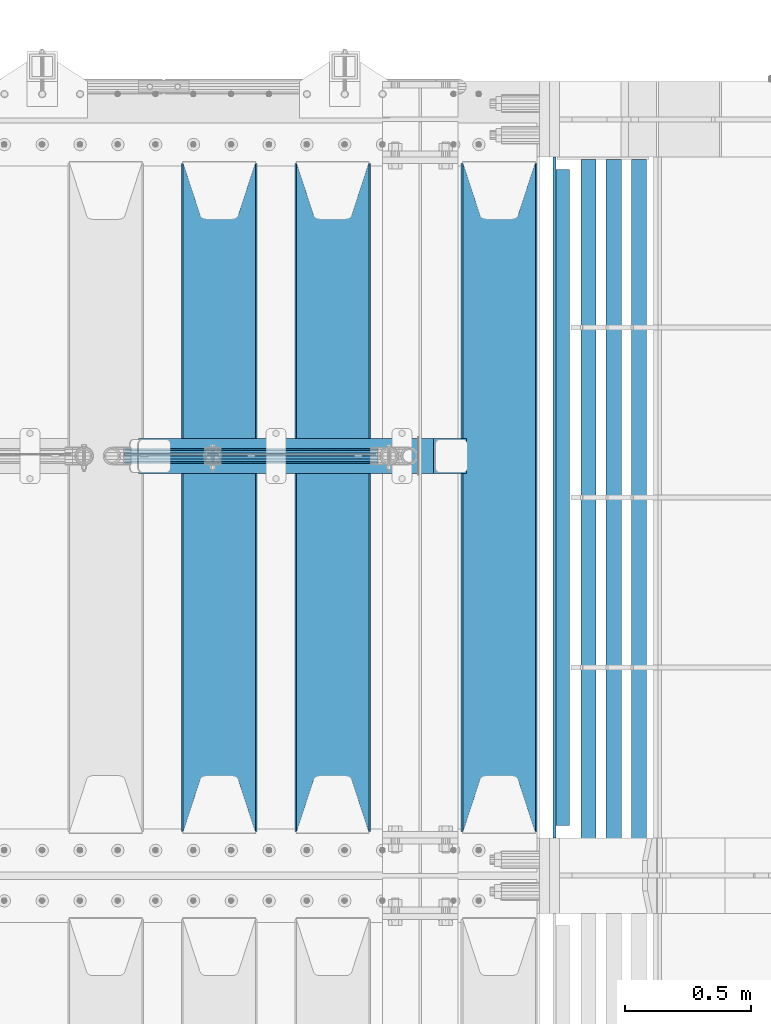
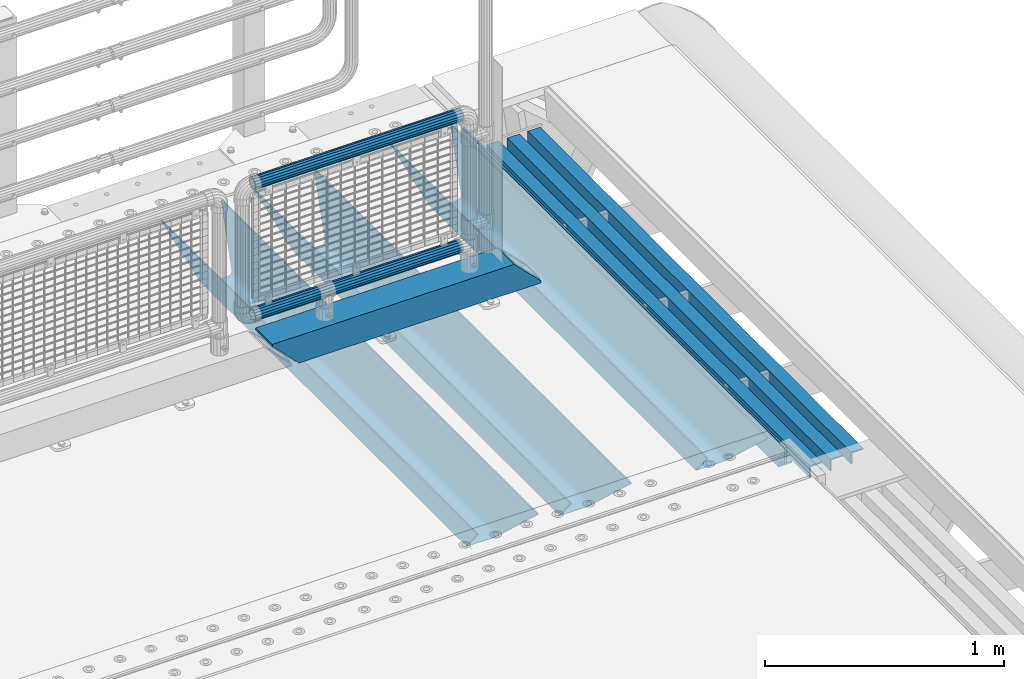
# One storey, part 136 of 242: 10 beams.
"""IFC2X3 building model written with IfcOpenShell, lengths in millimetres."""

from ifc_helpers import new_model, si_unit, frame, origin_with_axes, place, context, subcontext, project, spatial, faceted_brep, material, type_object, element, save


model = new_model("IFC2X3")

# Units and contexts
model_context = context("Model", 3, precision=1e-05, world=origin_with_axes())
body_context = subcontext(model_context, "Body", "Model", "MODEL_VIEW")
ifc_project = project(units=[si_unit("LENGTHUNIT", "METRE", prefix="MILLI"), si_unit("AREAUNIT", "SQUARE_METRE"), si_unit("VOLUMEUNIT", "CUBIC_METRE"), si_unit("MASSUNIT", "GRAM", prefix="KILO"), si_unit("TIMEUNIT", "SECOND"), si_unit("PLANEANGLEUNIT", "RADIAN"), si_unit("SOLIDANGLEUNIT", "STERADIAN"), si_unit("THERMODYNAMICTEMPERATUREUNIT", "DEGREE_CELSIUS"), si_unit("LUMINOUSINTENSITYUNIT", "LUMEN")], contexts=[model_context])

# Site, building, storey
site_placement = place(None, origin_with_axes())
site = spatial("IfcSite", under=ifc_project, at=site_placement, CompositionType="ELEMENT")
building_placement = place(site_placement, origin_with_axes())
building = spatial("IfcBuilding", under=site, at=building_placement, Name="Standard", CompositionType="ELEMENT")
storey_placement = place(building_placement, origin_with_axes())
storey = spatial("IfcBuildingStorey", under=building, at=storey_placement, Name="Undefined", CompositionType="ELEMENT", Elevation=0.0)

# Beams
ifc_material_1 = material()
beam_type_1 = type_object("IfcBeamType", PredefinedType="NOTDEFINED")
beam_1_placement = place(storey_placement, frame((-23705.4, -19335.5, 298.170000000001), z_axis=(0.0, 0.0, 1.0), x_axis=(1.0, 0.0, 0.0)))
element("IfcBeam", 1, at=beam_1_placement, inside=storey, type_object=beam_type_1, material=ifc_material_1, context=body_context, shape_type="Brep", body=[
    faceted_brep([(0.0, -25.3499999999985, 0.0), (0.0, -23.4203461491597, 9.70102501045403), (1005.0, -23.4203461491597, 9.70102501045506), (1005.0, -25.3499999999985, 0.0), (0.0, -17.9251569030785, 17.9251569030785), (1005.0, -17.9251569030785, 17.925156903079), (0.0, -9.70102501045403, 23.4203461491597), (1005.0, -9.70102501045403, 23.4203461491611), (0.0, 0.0, 25.3499999999985), (1005.0, 0.0, 25.35), (0.0, 9.70102501045403, 23.4203461491597), (1005.0, 9.70102501045403, 23.4203461491611), (0.0, 17.9251569030785, 17.9251569030785), (1005.0, 17.9251569030785, 17.925156903079), (0.0, 23.4203461491597, 9.70102501045403), (1005.0, 23.4203461491597, 9.701025010455), (0.0, 25.3499999999985, 0.0), (1005.0, 25.3499999999985, 0.0), (0.0, 23.4203461491597, -9.70102501045403), (1005.0, 23.4203461491597, -9.70102501045506), (0.0, 17.9251569030785, -17.9251569030785), (1005.0, 17.9251569030785, -17.925156903079), (0.0, 9.70102501045403, -23.4203461491597), (1005.0, 9.70102501045403, -23.4203461491611), (0.0, 0.0, -25.3499999999985), (1005.0, 0.0, -25.35), (0.0, -9.70102501045403, -23.4203461491597), (1005.0, -9.70102501045403, -23.4203461491611), (0.0, -17.9251569030785, -17.9251569030785), (1005.0, -17.9251569030785, -17.925156903079), (0.0, -23.4203461491597, -9.70102501045403), (1005.0, -23.4203461491597, -9.701025010455), (0.0, -30.1500000000015, 0.0), (0.0, -27.8549679052157, -11.5379054858058), (1005.0, -27.8549679052157, -11.5379054858075), (1005.0, -30.1500000000015, 0.0), (0.0, -21.3192694527752, -21.3192694527752), (1005.0, -21.3192694527752, -21.3192694527744), (0.0, -11.5379054858058, -27.8549679052157), (1005.0, -11.5379054858058, -27.8549679052153), (0.0, 0.0, -30.1500000000015), (1005.0, 0.0, -30.15), (0.0, 11.5379054858058, -27.8549679052157), (1005.0, 11.5379054858058, -27.8549679052153), (0.0, 21.3192694527752, -21.3192694527752), (1005.0, 21.3192694527752, -21.3192694527744), (0.0, 27.8549679052157, -11.5379054858058), (1005.0, 27.8549679052157, -11.5379054858075), (0.0, 30.1500000000015, 0.0), (1005.0, 30.1500000000015, 0.0), (0.0, 27.8549679052157, 11.5379054858058), (1005.0, 27.8549679052157, 11.5379054858075), (0.0, 21.3192694527752, 21.3192694527752), (1005.0, 21.3192694527752, 21.3192694527744), (0.0, 11.5379054858058, 27.8549679052157), (1005.0, 11.5379054858058, 27.8549679052153), (0.0, 0.0, 30.1500000000015), (1005.0, 0.0, 30.15), (0.0, -11.5379054858058, 27.8549679052157), (1005.0, -11.5379054858058, 27.8549679052153), (0.0, -21.3192694527752, 21.3192694527752), (1005.0, -21.3192694527752, 21.3192694527744), (0.0, -27.8549679052157, 11.5379054858058), (1005.0, -27.8549679052157, 11.5379054858075)], [[[0, 1, 2, 3]], [[1, 4, 5, 2]], [[4, 6, 7, 5]], [[6, 8, 9, 7]], [[8, 10, 11, 9]], [[10, 12, 13, 11]], [[12, 14, 15, 13]], [[14, 16, 17, 15]], [[16, 18, 19, 17]], [[18, 20, 21, 19]], [[20, 22, 23, 21]], [[22, 24, 25, 23]], [[24, 26, 27, 25]], [[26, 28, 29, 27]], [[28, 30, 31, 29]], [[30, 0, 3, 31]], [[32, 33, 34, 35]], [[33, 36, 37, 34]], [[36, 38, 39, 37]], [[38, 40, 41, 39]], [[40, 42, 43, 41]], [[42, 44, 45, 43]], [[44, 46, 47, 45]], [[46, 48, 49, 47]], [[48, 50, 51, 49]], [[50, 52, 53, 51]], [[52, 54, 55, 53]], [[54, 56, 57, 55]], [[56, 58, 59, 57]], [[58, 60, 61, 59]], [[60, 62, 63, 61]], [[62, 32, 35, 63]], [[37, 39, 41, 43, 45, 47, 49, 51, 53, 55, 57, 59, 61, 63, 35, 34], [5, 7, 9, 11, 13, 15, 17, 19, 21, 23, 25, 27, 29, 31, 3, 2]], [[62, 60, 58, 56, 54, 52, 50, 48, 46, 44, 42, 40, 38, 36, 33, 32], [30, 28, 26, 24, 22, 20, 18, 16, 14, 12, 10, 8, 6, 4, 1, 0]]]),
])
beam_2_placement = place(storey_placement, frame((-23706.0, -19335.5, 969.85), z_axis=(0.0, 0.0, 1.0), x_axis=(1.0, 0.0, 0.0)))
element("IfcBeam", 2, at=beam_2_placement, inside=storey, type_object=beam_type_1, material=ifc_material_1, context=body_context, shape_type="Brep", body=[
    faceted_brep([(0.0, -25.3499999999985, 0.0), (0.0, -23.4203461491597, 9.70102501045403), (1005.0, -23.4203461491597, 9.70102501045506), (1005.0, -25.3499999999985, 0.0), (0.0, -17.9251569030785, 17.9251569030785), (1005.0, -17.9251569030785, 17.925156903079), (0.0, -9.70102501045403, 23.4203461491597), (1005.0, -9.70102501045403, 23.4203461491611), (0.0, 0.0, 25.3499999999985), (1005.0, 0.0, 25.35), (0.0, 9.70102501045403, 23.4203461491597), (1005.0, 9.70102501045403, 23.4203461491611), (0.0, 17.9251569030785, 17.9251569030785), (1005.0, 17.9251569030785, 17.925156903079), (0.0, 23.4203461491597, 9.70102501045403), (1005.0, 23.4203461491597, 9.701025010455), (0.0, 25.3499999999985, 0.0), (1005.0, 25.3499999999985, 0.0), (0.0, 23.4203461491597, -9.70102501045403), (1005.0, 23.4203461491597, -9.70102501045506), (0.0, 17.9251569030785, -17.9251569030785), (1005.0, 17.9251569030785, -17.925156903079), (0.0, 9.70102501045403, -23.4203461491597), (1005.0, 9.70102501045403, -23.4203461491611), (0.0, 0.0, -25.3499999999985), (1005.0, 0.0, -25.35), (0.0, -9.70102501045403, -23.4203461491597), (1005.0, -9.70102501045403, -23.4203461491611), (0.0, -17.9251569030785, -17.9251569030785), (1005.0, -17.9251569030785, -17.925156903079), (0.0, -23.4203461491597, -9.70102501045403), (1005.0, -23.4203461491597, -9.701025010455), (0.0, -30.1500000000015, 0.0), (0.0, -27.8549679052157, -11.5379054858058), (1005.0, -27.8549679052157, -11.5379054858075), (1005.0, -30.1500000000015, 0.0), (0.0, -21.3192694527752, -21.3192694527752), (1005.0, -21.3192694527752, -21.3192694527744), (0.0, -11.5379054858058, -27.8549679052157), (1005.0, -11.5379054858058, -27.8549679052153), (0.0, 0.0, -30.1500000000015), (1005.0, 0.0, -30.15), (0.0, 11.5379054858058, -27.8549679052157), (1005.0, 11.5379054858058, -27.8549679052153), (0.0, 21.3192694527752, -21.3192694527752), (1005.0, 21.3192694527752, -21.3192694527744), (0.0, 27.8549679052157, -11.5379054858058), (1005.0, 27.8549679052157, -11.5379054858075), (0.0, 30.1500000000015, 0.0), (1005.0, 30.1500000000015, 0.0), (0.0, 27.8549679052157, 11.5379054858058), (1005.0, 27.8549679052157, 11.5379054858075), (0.0, 21.3192694527752, 21.3192694527752), (1005.0, 21.3192694527752, 21.3192694527744), (0.0, 11.5379054858058, 27.8549679052157), (1005.0, 11.5379054858058, 27.8549679052153), (0.0, 0.0, 30.1500000000015), (1005.0, 0.0, 30.15), (0.0, -11.5379054858058, 27.8549679052157), (1005.0, -11.5379054858058, 27.8549679052153), (0.0, -21.3192694527752, 21.3192694527752), (1005.0, -21.3192694527752, 21.3192694527744), (0.0, -27.8549679052157, 11.5379054858058), (1005.0, -27.8549679052157, 11.5379054858075)], [[[0, 1, 2, 3]], [[1, 4, 5, 2]], [[4, 6, 7, 5]], [[6, 8, 9, 7]], [[8, 10, 11, 9]], [[10, 12, 13, 11]], [[12, 14, 15, 13]], [[14, 16, 17, 15]], [[16, 18, 19, 17]], [[18, 20, 21, 19]], [[20, 22, 23, 21]], [[22, 24, 25, 23]], [[24, 26, 27, 25]], [[26, 28, 29, 27]], [[28, 30, 31, 29]], [[30, 0, 3, 31]], [[32, 33, 34, 35]], [[33, 36, 37, 34]], [[36, 38, 39, 37]], [[38, 40, 41, 39]], [[40, 42, 43, 41]], [[42, 44, 45, 43]], [[44, 46, 47, 45]], [[46, 48, 49, 47]], [[48, 50, 51, 49]], [[50, 52, 53, 51]], [[52, 54, 55, 53]], [[54, 56, 57, 55]], [[56, 58, 59, 57]], [[58, 60, 61, 59]], [[60, 62, 63, 61]], [[62, 32, 35, 63]], [[37, 39, 41, 43, 45, 47, 49, 51, 53, 55, 57, 59, 61, 63, 35, 34], [5, 7, 9, 11, 13, 15, 17, 19, 21, 23, 25, 27, 29, 31, 3, 2]], [[62, 60, 58, 56, 54, 52, 50, 48, 46, 44, 42, 40, 38, 36, 33, 32], [30, 28, 26, 24, 22, 20, 18, 16, 14, 12, 10, 8, 6, 4, 1, 0]]]),
])
beam_type_2 = type_object("IfcBeamType", PredefinedType="NOTDEFINED")
beam_3_placement = place(storey_placement, frame((-23650.0, -19335.5, 98.0199999999977), z_axis=(0.0, 0.0, 1.0), x_axis=(1.0, 0.0, 0.0)))
element("IfcBeam", 3, at=beam_3_placement, inside=storey, type_object=beam_type_2, material=ifc_material_1, context=body_context, shape_type="Brep", body=[
    faceted_brep([(0.0, 70.0, 70.0), (0.0, -70.0, 70.0), (1170.88846984783, -70.0, 70.0), (1170.88846984783, 70.0, 70.0), (1301.0, -60.0, -60.0), (1301.0, 60.0, -60.0), (119.989831466442, 60.0, -60.0), (119.989910626176, -60.0, -60.0), (1180.89643628727, -60.0, 60.0), (2.49929144047201e-09, -60.0000000000073, 60.0), (2.49928966411517e-09, 59.9999999999964, 60.0), (1180.89643628727, 60.0, 60.0), (1301.0, -70.0, -60.0079600980719), (1301.0, 70.0, -60.0079600980719), (1301.0, -70.0, -70.0), (1301.0, 70.0, -70.0), (129.999907566686, 70.0, -70.0), (0.0, 70.0, 59.8689646261584), (0.0, -70.0, 59.8690568861577), (129.99999991971, -70.0, -70.0)], [[[0, 1, 2, 3]], [[4, 5, 6, 7]], [[8, 4, 7, 9]], [[9, 10, 11, 8]], [[5, 11, 10, 6]], [[2, 12, 4, 8, 11, 5, 13, 3]], [[4, 12, 14, 15, 13, 5]], [[0, 3, 13, 15, 16, 17]], [[9, 18, 1, 0, 17, 10]], [[14, 12, 2, 1, 18, 19]], [[15, 14, 19, 16]], [[18, 9, 7, 6, 10, 17, 16, 19]]]),
])
ifc_material_2 = material(Name="STEEL/S355N")
beam_type_3 = type_object("IfcBeamType", PredefinedType="NOTDEFINED")
beam_4_placement = place(storey_placement, frame((-22220.0, -20825.0, -115.0), z_axis=(0.0, 0.0, 1.0), x_axis=(0.0, 1.0, 0.0)))
element("IfcBeam", 4, at=beam_4_placement, inside=storey, type_object=beam_type_3, material=ifc_material_2, context=body_context, shape_type="Brep", body=[
    faceted_brep([(0.0, 150.0, 115.0), (0.0, 143.689999999999, 115.0), (2650.00000000297, 143.689999999999, 115.0), (2650.00000000297, 150.0, 115.0), (2650.00000000297, 142.059565218402, 110.000000003099), (2650.00000000297, 148.369565218403, 110.000000003099), (2441.90079219209, -80.1103600731112, -98.0992078077845), (2437.7588105432, -77.5672621345584, -102.241189456673), (2434.06523489747, -74.4080125315522, -105.934765102404), (2430.91086095089, -70.710272125576, -109.089139048974), (2428.37322971128, -66.5649389910068, -111.626770288588), (2426.51472138055, -62.0739139532889, -113.485278619323), (2425.38102192092, -57.3475956567672, -114.618978078955), (2424.99999999987, -52.5021667386536, -115.0), (2424.99999999987, 52.5021667386536, -115.0), (2425.38102192092, 57.3475956567672, -114.618978078955), (2426.51472138055, 62.0739139532889, -113.485278619323), (2428.37322971128, 66.5649389910068, -111.626770288588), (2430.91086095089, 70.710272125576, -109.089139048974), (2434.06523489747, 74.4080125315522, -105.934765102404), (2437.7588105432, 77.5672621345584, -102.241189456673), (2441.90079219209, 80.1103600731112, -98.0992078077846), (2446.38936140511, 81.9747917625791, -93.6106385947584), (2448.2494850041, 76.2713538057251, -91.7505149957729), (2444.62967112262, 74.76777986261, -95.3703288772456), (2441.28936334126, 72.7168944282894, -98.710636658607), (2438.31067330438, 70.1691124903846, -101.689326695487), (2435.76682334747, 67.1870637758839, -104.233176652398), (2433.72034654133, 63.8440531834895, -106.279653458539), (2432.22154950042, 60.222258798236, -107.778450499454), (2431.30727574265, 56.4107117849089, -108.692724257221), (2430.99999999987, 52.5031078186876, -109.0), (2430.99999999987, -52.5031078186876, -109.0), (2431.30727574265, -56.4107117849089, -108.692724257221), (2432.22154950042, -60.222258798236, -107.778450499454), (2433.72034654133, -63.8440531834895, -106.279653458539), (2435.76682334747, -67.1870637758839, -104.233176652398), (2438.31067330438, -70.1691124903846, -101.689326695487), (2441.28936334126, -72.7168944282894, -98.7106366586071), (2444.62967112262, -74.76777986261, -95.3703288772457), (2448.2494850041, -76.2713538057251, -91.7505149957729), (2650.00000000297, -142.059565218402, 110.000000003099), (2650.00000000297, -148.369565218403, 110.000000003099), (2446.38936140511, -81.9747917625791, -93.6106385947584), (2650.00000000297, -143.689999999999, 115.0), (2650.00000000297, -150.0, 115.0), (0.0, -143.689999999999, 115.0), (0.0, -150.0, 115.0), (0.0, -148.369565218261, 110.000000002669), (203.610638597427, -81.9747917625791, -93.6106385947584), (208.099207810454, -80.1103600731112, -98.0992078077845), (212.241189459342, -77.5672621345584, -102.241189456673), (215.934765105074, -74.4080125315522, -105.934765102404), (219.089139051644, -70.710272125576, -109.089139048974), (221.626770291256, -66.5649389910068, -111.626770288588), (223.485278621993, -62.0739139532889, -113.485278619323), (224.618978081624, -57.3475956567672, -114.618978078955), (225.00000000267, -52.5021667386536, -115.0), (225.00000000267, 52.5021667386536, -115.0), (224.618978081624, 57.3475956567672, -114.618978078955), (223.485278621993, 62.0739139532889, -113.485278619323), (221.626770291256, 66.5649389910068, -111.626770288588), (219.089139051644, 70.710272125576, -109.089139048974), (215.934765105074, 74.4080125315522, -105.934765102404), (212.241189459342, 77.5672621345584, -102.241189456673), (208.099207810454, 80.1103600731112, -98.0992078077846), (203.610638597427, 81.9747917625791, -93.6106385947584), (0.0, 148.369565218261, 110.000000002669), (0.0, 142.05956521826, 110.000000002669), (201.750514998443, 76.2713538057251, -91.7505149957729), (205.370328879915, 74.76777986261, -95.3703288772456), (208.710636661275, 72.7168944282894, -98.710636658607), (211.689326698157, 70.1691124903846, -101.689326695487), (214.233176655067, 67.1870637758839, -104.233176652398), (216.279653461206, 63.8440531834895, -106.279653458539), (217.778450502123, 60.222258798236, -107.778450499454), (218.69272425989, 56.4107117849089, -108.692724257221), (219.00000000267, 52.5031078186876, -109.0), (219.00000000267, -52.5031078186876, -109.0), (218.69272425989, -56.4107117849089, -108.692724257221), (217.778450502123, -60.222258798236, -107.778450499454), (216.279653461206, -63.8440531834895, -106.279653458539), (214.233176655067, -67.1870637758839, -104.233176652398), (211.689326698157, -70.1691124903846, -101.689326695487), (208.710636661275, -72.7168944282894, -98.7106366586071), (205.370328879915, -74.76777986261, -95.3703288772457), (201.750514998443, -76.2713538057251, -91.7505149957729), (0.0, -142.05956521826, 110.000000002669)], [[[0, 1, 2, 3]], [[3, 2, 4, 5]], [[6, 7, 8, 9, 10, 11, 12, 13, 14, 15, 16, 17, 18, 19, 20, 21, 22, 5, 4, 23, 24, 25, 26, 27, 28, 29, 30, 31, 32, 33, 34, 35, 36, 37, 38, 39, 40, 41, 42, 43]], [[44, 45, 42, 41]], [[46, 47, 45, 44]], [[43, 42, 45, 47, 48, 49]], [[6, 43, 49, 50]], [[7, 6, 50, 51]], [[8, 7, 51, 52]], [[9, 8, 52, 53]], [[10, 9, 53, 54]], [[11, 10, 54, 55]], [[12, 11, 55, 56]], [[13, 12, 56, 57]], [[14, 13, 57, 58]], [[15, 14, 58, 59]], [[16, 15, 59, 60]], [[17, 16, 60, 61]], [[18, 17, 61, 62]], [[19, 18, 62, 63]], [[20, 19, 63, 64]], [[21, 20, 64, 65]], [[22, 21, 65, 66]], [[0, 3, 5, 22, 66, 67]], [[1, 0, 67, 68]], [[23, 4, 2, 1, 68, 69]], [[24, 23, 69, 70]], [[25, 24, 70, 71]], [[26, 25, 71, 72]], [[27, 26, 72, 73]], [[28, 27, 73, 74]], [[29, 28, 74, 75]], [[30, 29, 75, 76]], [[31, 30, 76, 77]], [[32, 31, 77, 78]], [[33, 32, 78, 79]], [[34, 33, 79, 80]], [[35, 34, 80, 81]], [[36, 35, 81, 82]], [[37, 36, 82, 83]], [[38, 37, 83, 84]], [[39, 38, 84, 85]], [[40, 39, 85, 86]], [[46, 44, 41, 40, 86, 87]], [[47, 46, 87, 48]], [[86, 85, 84, 83, 82, 81, 80, 79, 78, 77, 76, 75, 74, 73, 72, 71, 70, 69, 68, 67, 66, 65, 64, 63, 62, 61, 60, 59, 58, 57, 56, 55, 54, 53, 52, 51, 50, 49, 48, 87]]]),
])
beam_5_placement = place(storey_placement, frame((-22880.0, -20825.0, -115.0), z_axis=(0.0, 0.0, 1.0), x_axis=(0.0, 1.0, 0.0)))
element("IfcBeam", 5, at=beam_5_placement, inside=storey, type_object=beam_type_3, material=ifc_material_2, context=body_context, shape_type="Brep", body=[
    faceted_brep([(0.0, 150.0, 115.0), (0.0, 143.689999999999, 115.0), (2650.00000000297, 143.689999999999, 115.0), (2650.00000000297, 150.0, 115.0), (2650.00000000297, 142.059565218402, 110.000000003099), (2650.00000000297, 148.369565218403, 110.000000003099), (2441.90079219209, -80.1103600731112, -98.0992078077845), (2437.7588105432, -77.5672621345584, -102.241189456673), (2434.06523489747, -74.4080125315522, -105.934765102404), (2430.91086095089, -70.710272125576, -109.089139048974), (2428.37322971128, -66.5649389910068, -111.626770288588), (2426.51472138055, -62.0739139532889, -113.485278619323), (2425.38102192092, -57.3475956567672, -114.618978078955), (2424.99999999987, -52.5021667386536, -115.0), (2424.99999999987, 52.5021667386536, -115.0), (2425.38102192092, 57.3475956567672, -114.618978078955), (2426.51472138055, 62.0739139532889, -113.485278619323), (2428.37322971128, 66.5649389910068, -111.626770288588), (2430.91086095089, 70.710272125576, -109.089139048974), (2434.06523489747, 74.4080125315522, -105.934765102404), (2437.7588105432, 77.5672621345584, -102.241189456673), (2441.90079219209, 80.1103600731112, -98.0992078077846), (2446.38936140511, 81.9747917625791, -93.6106385947584), (2448.2494850041, 76.2713538057251, -91.7505149957729), (2444.62967112262, 74.76777986261, -95.3703288772456), (2441.28936334126, 72.7168944282894, -98.710636658607), (2438.31067330438, 70.1691124903846, -101.689326695487), (2435.76682334747, 67.1870637758839, -104.233176652398), (2433.72034654133, 63.8440531834895, -106.279653458539), (2432.22154950042, 60.222258798236, -107.778450499454), (2431.30727574265, 56.4107117849089, -108.692724257221), (2430.99999999987, 52.5031078186876, -109.0), (2430.99999999987, -52.5031078186876, -109.0), (2431.30727574265, -56.4107117849089, -108.692724257221), (2432.22154950042, -60.222258798236, -107.778450499454), (2433.72034654133, -63.8440531834895, -106.279653458539), (2435.76682334747, -67.1870637758839, -104.233176652398), (2438.31067330438, -70.1691124903846, -101.689326695487), (2441.28936334126, -72.7168944282894, -98.7106366586071), (2444.62967112262, -74.76777986261, -95.3703288772457), (2448.2494850041, -76.2713538057251, -91.7505149957729), (2650.00000000297, -142.059565218402, 110.000000003099), (2650.00000000297, -148.369565218403, 110.000000003099), (2446.38936140511, -81.9747917625791, -93.6106385947584), (2650.00000000297, -143.689999999999, 115.0), (2650.00000000297, -150.0, 115.0), (0.0, -143.689999999999, 115.0), (0.0, -150.0, 115.0), (0.0, -148.369565218261, 110.000000002669), (203.610638597427, -81.9747917625791, -93.6106385947584), (208.099207810454, -80.1103600731112, -98.0992078077845), (212.241189459342, -77.5672621345584, -102.241189456673), (215.934765105074, -74.4080125315522, -105.934765102404), (219.089139051644, -70.710272125576, -109.089139048974), (221.626770291256, -66.5649389910068, -111.626770288588), (223.485278621993, -62.0739139532889, -113.485278619323), (224.618978081624, -57.3475956567672, -114.618978078955), (225.00000000267, -52.5021667386536, -115.0), (225.00000000267, 52.5021667386536, -115.0), (224.618978081624, 57.3475956567672, -114.618978078955), (223.485278621993, 62.0739139532889, -113.485278619323), (221.626770291256, 66.5649389910068, -111.626770288588), (219.089139051644, 70.710272125576, -109.089139048974), (215.934765105074, 74.4080125315522, -105.934765102404), (212.241189459342, 77.5672621345584, -102.241189456673), (208.099207810454, 80.1103600731112, -98.0992078077846), (203.610638597427, 81.9747917625791, -93.6106385947584), (0.0, 148.369565218261, 110.000000002669), (0.0, 142.05956521826, 110.000000002669), (201.750514998443, 76.2713538057251, -91.7505149957729), (205.370328879915, 74.76777986261, -95.3703288772456), (208.710636661275, 72.7168944282894, -98.710636658607), (211.689326698157, 70.1691124903846, -101.689326695487), (214.233176655067, 67.1870637758839, -104.233176652398), (216.279653461206, 63.8440531834895, -106.279653458539), (217.778450502123, 60.222258798236, -107.778450499454), (218.69272425989, 56.4107117849089, -108.692724257221), (219.00000000267, 52.5031078186876, -109.0), (219.00000000267, -52.5031078186876, -109.0), (218.69272425989, -56.4107117849089, -108.692724257221), (217.778450502123, -60.222258798236, -107.778450499454), (216.279653461206, -63.8440531834895, -106.279653458539), (214.233176655067, -67.1870637758839, -104.233176652398), (211.689326698157, -70.1691124903846, -101.689326695487), (208.710636661275, -72.7168944282894, -98.7106366586071), (205.370328879915, -74.76777986261, -95.3703288772457), (201.750514998443, -76.2713538057251, -91.7505149957729), (0.0, -142.05956521826, 110.000000002669)], [[[0, 1, 2, 3]], [[3, 2, 4, 5]], [[6, 7, 8, 9, 10, 11, 12, 13, 14, 15, 16, 17, 18, 19, 20, 21, 22, 5, 4, 23, 24, 25, 26, 27, 28, 29, 30, 31, 32, 33, 34, 35, 36, 37, 38, 39, 40, 41, 42, 43]], [[44, 45, 42, 41]], [[46, 47, 45, 44]], [[43, 42, 45, 47, 48, 49]], [[6, 43, 49, 50]], [[7, 6, 50, 51]], [[8, 7, 51, 52]], [[9, 8, 52, 53]], [[10, 9, 53, 54]], [[11, 10, 54, 55]], [[12, 11, 55, 56]], [[13, 12, 56, 57]], [[14, 13, 57, 58]], [[15, 14, 58, 59]], [[16, 15, 59, 60]], [[17, 16, 60, 61]], [[18, 17, 61, 62]], [[19, 18, 62, 63]], [[20, 19, 63, 64]], [[21, 20, 64, 65]], [[22, 21, 65, 66]], [[0, 3, 5, 22, 66, 67]], [[1, 0, 67, 68]], [[23, 4, 2, 1, 68, 69]], [[24, 23, 69, 70]], [[25, 24, 70, 71]], [[26, 25, 71, 72]], [[27, 26, 72, 73]], [[28, 27, 73, 74]], [[29, 28, 74, 75]], [[30, 29, 75, 76]], [[31, 30, 76, 77]], [[32, 31, 77, 78]], [[33, 32, 78, 79]], [[34, 33, 79, 80]], [[35, 34, 80, 81]], [[36, 35, 81, 82]], [[37, 36, 82, 83]], [[38, 37, 83, 84]], [[39, 38, 84, 85]], [[40, 39, 85, 86]], [[46, 44, 41, 40, 86, 87]], [[47, 46, 87, 48]], [[86, 85, 84, 83, 82, 81, 80, 79, 78, 77, 76, 75, 74, 73, 72, 71, 70, 69, 68, 67, 66, 65, 64, 63, 62, 61, 60, 59, 58, 57, 56, 55, 54, 53, 52, 51, 50, 49, 48, 87]]]),
])
beam_6_placement = place(storey_placement, frame((-23330.0, -20825.0, -115.0), z_axis=(0.0, 0.0, 1.0), x_axis=(0.0, 1.0, 0.0)))
element("IfcBeam", 6, at=beam_6_placement, inside=storey, type_object=beam_type_3, material=ifc_material_2, context=body_context, shape_type="Brep", body=[
    faceted_brep([(0.0, 150.0, 115.0), (0.0, 143.689999999999, 115.0), (2650.00000000297, 143.689999999999, 115.0), (2650.00000000297, 150.0, 115.0), (2650.00000000297, 142.059565218402, 110.000000003099), (2650.00000000297, 148.369565218403, 110.000000003099), (2441.90079219209, -80.1103600731112, -98.0992078077845), (2437.7588105432, -77.5672621345584, -102.241189456673), (2434.06523489747, -74.4080125315522, -105.934765102404), (2430.91086095089, -70.710272125576, -109.089139048974), (2428.37322971128, -66.5649389910068, -111.626770288588), (2426.51472138055, -62.0739139532889, -113.485278619323), (2425.38102192092, -57.3475956567672, -114.618978078955), (2424.99999999987, -52.5021667386536, -115.0), (2424.99999999987, 52.5021667386536, -115.0), (2425.38102192092, 57.3475956567672, -114.618978078955), (2426.51472138055, 62.0739139532889, -113.485278619323), (2428.37322971128, 66.5649389910068, -111.626770288588), (2430.91086095089, 70.710272125576, -109.089139048974), (2434.06523489747, 74.4080125315522, -105.934765102404), (2437.7588105432, 77.5672621345584, -102.241189456673), (2441.90079219209, 80.1103600731112, -98.0992078077846), (2446.38936140511, 81.9747917625791, -93.6106385947584), (2448.2494850041, 76.2713538057251, -91.7505149957729), (2444.62967112262, 74.76777986261, -95.3703288772456), (2441.28936334126, 72.7168944282894, -98.710636658607), (2438.31067330438, 70.1691124903846, -101.689326695487), (2435.76682334747, 67.1870637758839, -104.233176652398), (2433.72034654133, 63.8440531834895, -106.279653458539), (2432.22154950042, 60.222258798236, -107.778450499454), (2431.30727574265, 56.4107117849089, -108.692724257221), (2430.99999999987, 52.5031078186876, -109.0), (2430.99999999987, -52.5031078186876, -109.0), (2431.30727574265, -56.4107117849089, -108.692724257221), (2432.22154950042, -60.222258798236, -107.778450499454), (2433.72034654133, -63.8440531834895, -106.279653458539), (2435.76682334747, -67.1870637758839, -104.233176652398), (2438.31067330438, -70.1691124903846, -101.689326695487), (2441.28936334126, -72.7168944282894, -98.7106366586071), (2444.62967112262, -74.76777986261, -95.3703288772457), (2448.2494850041, -76.2713538057251, -91.7505149957729), (2650.00000000297, -142.059565218402, 110.000000003099), (2650.00000000297, -148.369565218403, 110.000000003099), (2446.38936140511, -81.9747917625791, -93.6106385947584), (2650.00000000297, -143.689999999999, 115.0), (2650.00000000297, -150.0, 115.0), (0.0, -143.689999999999, 115.0), (0.0, -150.0, 115.0), (0.0, -148.369565218261, 110.000000002669), (203.610638597427, -81.9747917625791, -93.6106385947584), (208.099207810454, -80.1103600731112, -98.0992078077845), (212.241189459342, -77.5672621345584, -102.241189456673), (215.934765105074, -74.4080125315522, -105.934765102404), (219.089139051644, -70.710272125576, -109.089139048974), (221.626770291256, -66.5649389910068, -111.626770288588), (223.485278621993, -62.0739139532889, -113.485278619323), (224.618978081624, -57.3475956567672, -114.618978078955), (225.00000000267, -52.5021667386536, -115.0), (225.00000000267, 52.5021667386536, -115.0), (224.618978081624, 57.3475956567672, -114.618978078955), (223.485278621993, 62.0739139532889, -113.485278619323), (221.626770291256, 66.5649389910068, -111.626770288588), (219.089139051644, 70.710272125576, -109.089139048974), (215.934765105074, 74.4080125315522, -105.934765102404), (212.241189459342, 77.5672621345584, -102.241189456673), (208.099207810454, 80.1103600731112, -98.0992078077846), (203.610638597427, 81.9747917625791, -93.6106385947584), (0.0, 148.369565218261, 110.000000002669), (0.0, 142.05956521826, 110.000000002669), (201.750514998443, 76.2713538057251, -91.7505149957729), (205.370328879915, 74.76777986261, -95.3703288772456), (208.710636661275, 72.7168944282894, -98.710636658607), (211.689326698157, 70.1691124903846, -101.689326695487), (214.233176655067, 67.1870637758839, -104.233176652398), (216.279653461206, 63.8440531834895, -106.279653458539), (217.778450502123, 60.222258798236, -107.778450499454), (218.69272425989, 56.4107117849089, -108.692724257221), (219.00000000267, 52.5031078186876, -109.0), (219.00000000267, -52.5031078186876, -109.0), (218.69272425989, -56.4107117849089, -108.692724257221), (217.778450502123, -60.222258798236, -107.778450499454), (216.279653461206, -63.8440531834895, -106.279653458539), (214.233176655067, -67.1870637758839, -104.233176652398), (211.689326698157, -70.1691124903846, -101.689326695487), (208.710636661275, -72.7168944282894, -98.7106366586071), (205.370328879915, -74.76777986261, -95.3703288772457), (201.750514998443, -76.2713538057251, -91.7505149957729), (0.0, -142.05956521826, 110.000000002669)], [[[0, 1, 2, 3]], [[3, 2, 4, 5]], [[6, 7, 8, 9, 10, 11, 12, 13, 14, 15, 16, 17, 18, 19, 20, 21, 22, 5, 4, 23, 24, 25, 26, 27, 28, 29, 30, 31, 32, 33, 34, 35, 36, 37, 38, 39, 40, 41, 42, 43]], [[44, 45, 42, 41]], [[46, 47, 45, 44]], [[43, 42, 45, 47, 48, 49]], [[6, 43, 49, 50]], [[7, 6, 50, 51]], [[8, 7, 51, 52]], [[9, 8, 52, 53]], [[10, 9, 53, 54]], [[11, 10, 54, 55]], [[12, 11, 55, 56]], [[13, 12, 56, 57]], [[14, 13, 57, 58]], [[15, 14, 58, 59]], [[16, 15, 59, 60]], [[17, 16, 60, 61]], [[18, 17, 61, 62]], [[19, 18, 62, 63]], [[20, 19, 63, 64]], [[21, 20, 64, 65]], [[22, 21, 65, 66]], [[0, 3, 5, 22, 66, 67]], [[1, 0, 67, 68]], [[23, 4, 2, 1, 68, 69]], [[24, 23, 69, 70]], [[25, 24, 70, 71]], [[26, 25, 71, 72]], [[27, 26, 72, 73]], [[28, 27, 73, 74]], [[29, 28, 74, 75]], [[30, 29, 75, 76]], [[31, 30, 76, 77]], [[32, 31, 77, 78]], [[33, 32, 78, 79]], [[34, 33, 79, 80]], [[35, 34, 80, 81]], [[36, 35, 81, 82]], [[37, 36, 82, 83]], [[38, 37, 83, 84]], [[39, 38, 84, 85]], [[40, 39, 85, 86]], [[46, 44, 41, 40, 86, 87]], [[47, 46, 87, 48]], [[86, 85, 84, 83, 82, 81, 80, 79, 78, 77, 76, 75, 74, 73, 72, 71, 70, 69, 68, 67, 66, 65, 64, 63, 62, 61, 60, 59, 58, 57, 56, 55, 54, 53, 52, 51, 50, 49, 48, 87]]]),
])
ifc_material_3 = material(Name="STEEL/S355J2")
beam_type_4 = type_object("IfcBeamType", PredefinedType="NOTDEFINED")
beam_7_placement = place(storey_placement, frame((-21972.4974739935, -20850.0, -124.999999999993), z_axis=(0.0, 0.0, 1.0), x_axis=(0.0, 1.0, 0.0)))
element("IfcBeam", 7, at=beam_7_placement, inside=storey, type_object=beam_type_4, material=ifc_material_3, context=body_context, shape_type="Brep", body=[
    faceted_brep([(2700.0, 22.5, -15.0), (2684.54915028125, 22.5000000000036, -17.4471741852423), (2684.54915028125, 32.5000000000036, -17.4471741852423), (2700.0, 32.5, -15.0), (2670.61073738538, 22.5000000000036, -24.5491502812526), (2670.61073738538, 32.5000000000036, -24.5491502812526), (2659.54915028125, 22.5000000000036, -35.6107373853764), (2659.54915028125, 32.5000000000036, -35.6107373853764), (2652.44717418524, 22.5000000000036, -49.5491502812526), (2652.44717418524, 32.5000000000036, -49.5491502812526), (2651.58384440325, -32.5, -55.0), (2650.0, -32.5, -65.0), (2650.0, 32.5, -65.0), (2651.58384440325, 22.5, -55.0), (0.0, 32.5, 65.0), (0.0, 22.5, 65.0), (2700.0, 22.5, 65.0), (2700.0, 32.5, 65.0), (0.0, 32.5, -15.0), (0.0, 22.5, -15.0), (15.4508497187489, 32.5, -17.4471741852423), (15.4508497187489, 22.5, -17.4471741852423), (29.3892626146226, 32.5, -24.5491502812526), (29.3892626146226, 22.5, -24.5491502812526), (40.4508497187489, 32.5, -35.6107373853764), (40.4508497187489, 22.5, -35.6107373853764), (47.5528258147569, 32.5, -49.5491502812526), (47.5528258147569, 22.5, -49.5491502812526), (50.0, -32.5, -65.0), (48.4161555967548, -32.5, -55.0), (48.4161555967548, 22.5, -55.0), (50.0, 32.5, -65.0)], [[[0, 1, 2, 3]], [[4, 5, 2, 1]], [[6, 7, 5, 4]], [[8, 9, 7, 6]], [[10, 11, 12, 9, 8, 13]], [[14, 15, 16, 17]], [[15, 14, 18, 19]], [[19, 18, 20, 21]], [[21, 20, 22, 23]], [[23, 22, 24, 25]], [[25, 24, 26, 27]], [[28, 29, 30, 27, 26, 31]], [[30, 29, 10, 13]], [[16, 15, 19, 21, 23, 25, 27, 30, 13, 8, 6, 4, 1, 0]], [[17, 16, 0, 3]], [[5, 7, 9, 12, 31, 26, 24, 22, 20, 18, 14, 17, 3, 2]], [[28, 31, 12, 11]], [[29, 28, 11, 10]]]),
])
beam_type_5 = type_object("IfcBeamType", PredefinedType="NOTDEFINED")
for number, where, z_axis, x_axis in (
    (8, (-21665.001170099, -18160.0000995858, -209.999999999564), (0.0, 0.0, -1.0), (0.0, -1.0, 0.0)),
    (9, (-21765.001170099, -18160.0000995857, -209.999999999564), (0.0, 0.0, -1.0), (0.0, -1.0, 0.0)),
    (10, (-21865.0011700997, -18159.9999976612, -209.999999999622), (0.0, 0.0, -1.0), (0.0, -1.0, 0.0)),
):
    element("IfcBeam", number, at=place(storey_placement, frame(where, z_axis=z_axis, x_axis=x_axis)), inside=storey, type_object=beam_type_5, material=ifc_material_3, context=body_context, shape_type="Brep", body=[
        faceted_brep([(3.63797880709171e-12, 30.0, -30.0), (0.0, 30.0, 30.0000000000001), (2710.00017042501, 30.0000000000036, 30.0), (2710.00017042501, 30.0000000000036, -30.0), (0.0, 24.0, 30.0), (2710.00017042501, 24.0000000000036, 30.0), (0.0, 24.0, -24.0), (2710.00017042501, 24.0000000000036, -24.0), (3.63797880709171e-12, -30.0, -24.0), (2710.00017042501, -29.9999999999964, -24.0), (3.63797880709171e-12, -30.0, -30.0), (2710.00017042501, -29.9999999999964, -30.0)], [[[0, 1, 2, 3]], [[1, 4, 5, 2]], [[4, 6, 7, 5]], [[6, 8, 9, 7]], [[8, 10, 11, 9]], [[10, 0, 3, 11]], [[5, 7, 9, 11, 3, 2]], [[10, 8, 6, 4, 1, 0]]]),
    ])

save(model, "model.ifc")
